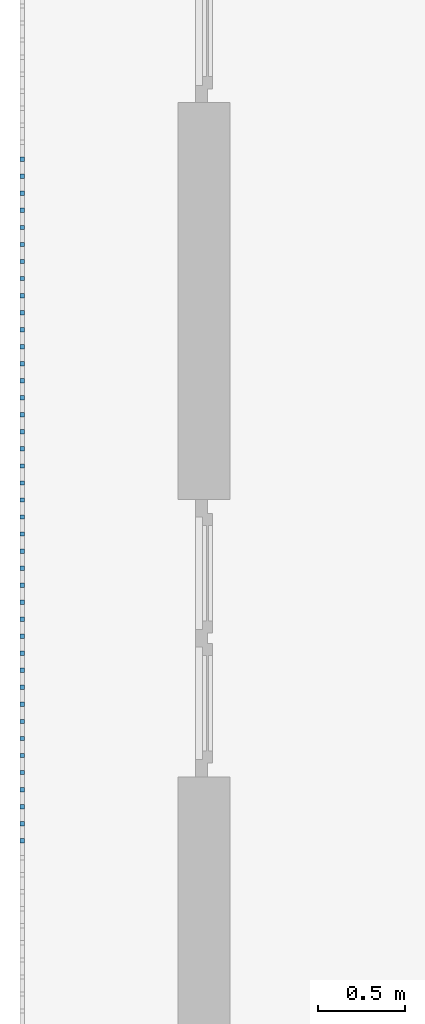
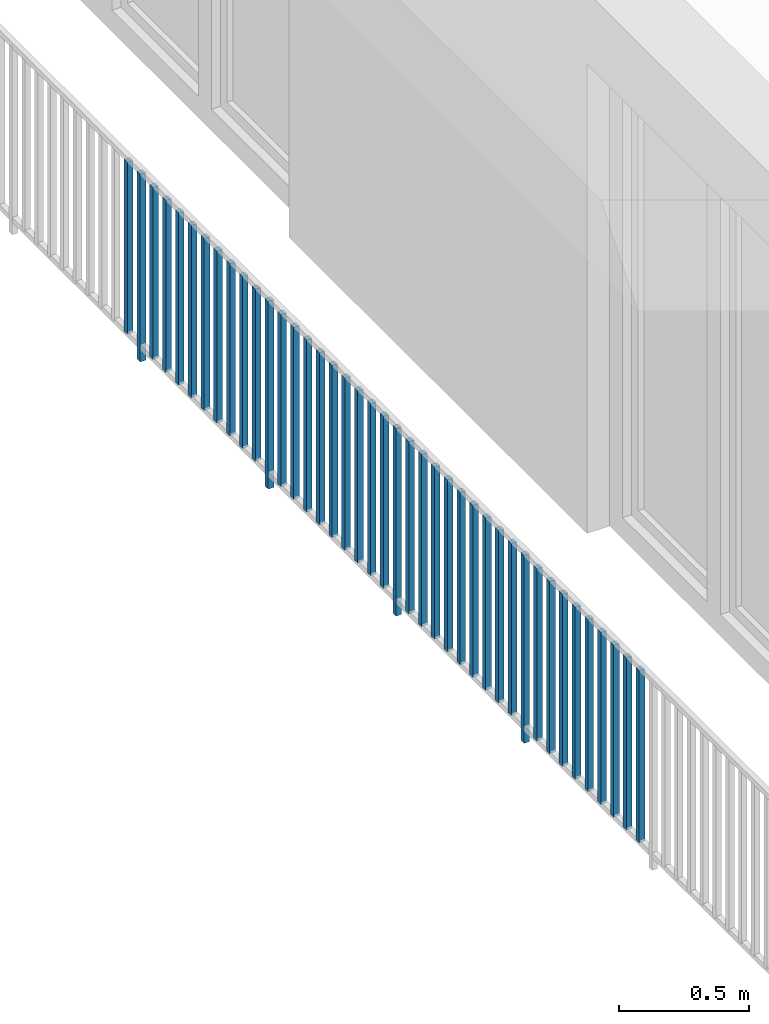
# One storey, part 28 of 48: 41 building element parts, 1 element without a shape of its own.
"""IFC4 building model written with IfcOpenShell, lengths in metres."""

from ifc_helpers import new_model, entity, si_unit, converted_unit, derived_unit, direction, frame, origin_with_axes, place, context, subcontext, project, spatial, polygons, material, type_object, element, aggregate, save


model = new_model("IFC4")

# Units and contexts
model_context = context("Model", 3, precision=1e-05, world=origin_with_axes(), true_north=direction((0.0, 1.0)))
body_context = subcontext(model_context, "Body", "Model", "MODEL_VIEW")
ifc_project = project(units=[si_unit("LENGTHUNIT", "METRE"), si_unit("AREAUNIT", "SQUARE_METRE"), si_unit("VOLUMEUNIT", "CUBIC_METRE"), converted_unit("PLANEANGLEUNIT", "DEGREE", entity("IfcPlaneAngleMeasure", 0.0174532925199), si_unit("PLANEANGLEUNIT", "RADIAN"), dimensions=[0, 0, 0, 0, 0, 0, 0]), converted_unit("TIMEUNIT", "Year", entity("IfcTimeMeasure", 31556926.0), si_unit("TIMEUNIT", "SECOND"), dimensions=[0, 0, 1, 0, 0, 0, 0]), si_unit("MASSUNIT", "GRAM", prefix="KILO"), si_unit("THERMODYNAMICTEMPERATUREUNIT", "DEGREE_CELSIUS"), si_unit("LUMINOUSINTENSITYUNIT", "LUMEN"), si_unit("ENERGYUNIT", "JOULE", prefix="MEGA"), derived_unit("THERMALCONDUCTANCEUNIT", [(si_unit("POWERUNIT", "WATT"), 1), (si_unit("LENGTHUNIT", "METRE"), -1), (si_unit("THERMODYNAMICTEMPERATUREUNIT", "KELVIN"), -1)]), derived_unit("SPECIFICHEATCAPACITYUNIT", [(si_unit("ENERGYUNIT", "JOULE"), 1), (si_unit("MASSUNIT", "GRAM", prefix="KILO"), -1), (si_unit("THERMODYNAMICTEMPERATUREUNIT", "KELVIN"), -1)]), derived_unit("MASSDENSITYUNIT", [(si_unit("MASSUNIT", "GRAM", prefix="KILO"), 1), (si_unit("VOLUMEUNIT", "CUBIC_METRE"), -1)])], contexts=[model_context])

# Site, building, storey
site_placement = place(None, origin_with_axes())
site = spatial("IfcSite", under=ifc_project, at=site_placement, CompositionType="ELEMENT")
building_placement = place(site_placement, origin_with_axes())
building = spatial("IfcBuilding", under=site, at=building_placement, CompositionType="ELEMENT")
storey_placement = place(building_placement, frame((0.0, 0.0, 3.4), z_axis=(0.0, 0.0, 1.0), x_axis=(1.0, 0.0, 0.0)))
storey = spatial("IfcBuildingStorey", under=building, at=storey_placement, Name="1. Geschoss", CompositionType="ELEMENT", Elevation=3.4)

# Railing, building element parts
railing_type = type_object("IfcRailingType", PredefinedType="NOTDEFINED")
railing_placement = place(storey_placement, frame((10.2378006196, 9.82118776896, 0.0), z_axis=(0.0, 0.0, 1.0), x_axis=(1.0, 0.0, 0.0)))
railing = element("IfcRailing", 1, at=railing_placement, inside=storey, type_object=railing_type, PredefinedType="NOTDEFINED")
ifc_material = material()
building_element_part_1_placement = place(railing_placement, origin_with_axes())
building_element_part_1 = element("IfcBuildingElementPart", 2, at=building_element_part_1_placement, material=ifc_material, PredefinedType="NOTDEFINED", context=body_context, shape_type="Tessellation", body=[
    polygons([(-22.8925, -12.6975, 0.07), (-22.8675, -12.6975, 0.07), (-22.8675, -12.6975, 0.8775), (-22.8925, -12.6975, 0.8775), (-22.8925, -12.6725, 0.07), (-22.8675, -12.6725, 0.07), (-22.8675, -12.6725, 0.8775), (-22.8925, -12.6725, 0.8775)], [[[1, 2, 3, 4]], [[1, 5, 6, 2]], [[2, 6, 7, 3]], [[4, 3, 7, 8]], [[5, 1, 4, 8]], [[6, 5, 8, 7]]], closed=True),
])
building_element_part_2_placement = place(railing_placement, origin_with_axes())
building_element_part_2 = element("IfcBuildingElementPart", 3, at=building_element_part_2_placement, material=ifc_material, PredefinedType="NOTDEFINED", context=body_context, shape_type="Tessellation", body=[
    polygons([(-22.8925, -12.7958333333, 0.0), (-22.8675, -12.7958333333, 0.0), (-22.8675, -12.7958333333, 0.88), (-22.8925, -12.7958333333, 0.88), (-22.8925, -12.7708333333, 0.0), (-22.8675, -12.7708333333, 0.0), (-22.8675, -12.7708333333, 0.88), (-22.8925, -12.7708333333, 0.88)], [[[1, 2, 3, 4]], [[1, 5, 6, 2]], [[2, 6, 7, 3]], [[4, 3, 7, 8]], [[5, 1, 4, 8]], [[6, 5, 8, 7]]], closed=True),
])
building_element_part_3_placement = place(railing_placement, origin_with_axes())
building_element_part_3 = element("IfcBuildingElementPart", 4, at=building_element_part_3_placement, material=ifc_material, PredefinedType="NOTDEFINED", context=body_context, shape_type="Tessellation", body=[
    polygons([(-22.8925, -12.8941666667, 0.07), (-22.8675, -12.8941666667, 0.07), (-22.8675, -12.8941666667, 0.8775), (-22.8925, -12.8941666667, 0.8775), (-22.8925, -12.8691666667, 0.07), (-22.8675, -12.8691666667, 0.07), (-22.8675, -12.8691666667, 0.8775), (-22.8925, -12.8691666667, 0.8775)], [[[1, 2, 3, 4]], [[1, 5, 6, 2]], [[2, 6, 7, 3]], [[4, 3, 7, 8]], [[5, 1, 4, 8]], [[6, 5, 8, 7]]], closed=True),
])
building_element_part_4_placement = place(railing_placement, origin_with_axes())
building_element_part_4 = element("IfcBuildingElementPart", 5, at=building_element_part_4_placement, material=ifc_material, PredefinedType="NOTDEFINED", context=body_context, shape_type="Tessellation", body=[
    polygons([(-22.8925, -12.9925, 0.07), (-22.8675, -12.9925, 0.07), (-22.8675, -12.9925, 0.8775), (-22.8925, -12.9925, 0.8775), (-22.8925, -12.9675, 0.07), (-22.8675, -12.9675, 0.07), (-22.8675, -12.9675, 0.8775), (-22.8925, -12.9675, 0.8775)], [[[1, 2, 3, 4]], [[1, 5, 6, 2]], [[2, 6, 7, 3]], [[4, 3, 7, 8]], [[5, 1, 4, 8]], [[6, 5, 8, 7]]], closed=True),
])
building_element_part_5_placement = place(railing_placement, origin_with_axes())
building_element_part_5 = element("IfcBuildingElementPart", 6, at=building_element_part_5_placement, material=ifc_material, PredefinedType="NOTDEFINED", context=body_context, shape_type="Tessellation", body=[
    polygons([(-22.8925, -13.0908333333, 0.07), (-22.8675, -13.0908333333, 0.07), (-22.8675, -13.0908333333, 0.8775), (-22.8925, -13.0908333333, 0.8775), (-22.8925, -13.0658333333, 0.07), (-22.8675, -13.0658333333, 0.07), (-22.8675, -13.0658333333, 0.8775), (-22.8925, -13.0658333333, 0.8775)], [[[1, 2, 3, 4]], [[1, 5, 6, 2]], [[2, 6, 7, 3]], [[4, 3, 7, 8]], [[5, 1, 4, 8]], [[6, 5, 8, 7]]], closed=True),
])
building_element_part_6_placement = place(railing_placement, origin_with_axes())
building_element_part_6 = element("IfcBuildingElementPart", 7, at=building_element_part_6_placement, material=ifc_material, PredefinedType="NOTDEFINED", context=body_context, shape_type="Tessellation", body=[
    polygons([(-22.8925, -13.1891666667, 0.07), (-22.8675, -13.1891666667, 0.07), (-22.8675, -13.1891666667, 0.8775), (-22.8925, -13.1891666667, 0.8775), (-22.8925, -13.1641666667, 0.07), (-22.8675, -13.1641666667, 0.07), (-22.8675, -13.1641666667, 0.8775), (-22.8925, -13.1641666667, 0.8775)], [[[1, 2, 3, 4]], [[1, 5, 6, 2]], [[2, 6, 7, 3]], [[4, 3, 7, 8]], [[5, 1, 4, 8]], [[6, 5, 8, 7]]], closed=True),
])
building_element_part_7_placement = place(railing_placement, origin_with_axes())
building_element_part_7 = element("IfcBuildingElementPart", 8, at=building_element_part_7_placement, material=ifc_material, PredefinedType="NOTDEFINED", context=body_context, shape_type="Tessellation", body=[
    polygons([(-22.8925, -13.2875, 0.07), (-22.8675, -13.2875, 0.07), (-22.8675, -13.2875, 0.8775), (-22.8925, -13.2875, 0.8775), (-22.8925, -13.2625, 0.07), (-22.8675, -13.2625, 0.07), (-22.8675, -13.2625, 0.8775), (-22.8925, -13.2625, 0.8775)], [[[1, 2, 3, 4]], [[1, 5, 6, 2]], [[2, 6, 7, 3]], [[4, 3, 7, 8]], [[5, 1, 4, 8]], [[6, 5, 8, 7]]], closed=True),
])
building_element_part_8_placement = place(railing_placement, origin_with_axes())
building_element_part_8 = element("IfcBuildingElementPart", 9, at=building_element_part_8_placement, material=ifc_material, PredefinedType="NOTDEFINED", context=body_context, shape_type="Tessellation", body=[
    polygons([(-22.8925, -13.3858333333, 0.07), (-22.8675, -13.3858333333, 0.07), (-22.8675, -13.3858333333, 0.8775), (-22.8925, -13.3858333333, 0.8775), (-22.8925, -13.3608333333, 0.07), (-22.8675, -13.3608333333, 0.07), (-22.8675, -13.3608333333, 0.8775), (-22.8925, -13.3608333333, 0.8775)], [[[1, 2, 3, 4]], [[1, 5, 6, 2]], [[2, 6, 7, 3]], [[4, 3, 7, 8]], [[5, 1, 4, 8]], [[6, 5, 8, 7]]], closed=True),
])
building_element_part_9_placement = place(railing_placement, origin_with_axes())
building_element_part_9 = element("IfcBuildingElementPart", 10, at=building_element_part_9_placement, material=ifc_material, PredefinedType="NOTDEFINED", context=body_context, shape_type="Tessellation", body=[
    polygons([(-22.8925, -13.4841666667, 0.07), (-22.8675, -13.4841666667, 0.07), (-22.8675, -13.4841666667, 0.8775), (-22.8925, -13.4841666667, 0.8775), (-22.8925, -13.4591666667, 0.07), (-22.8675, -13.4591666667, 0.07), (-22.8675, -13.4591666667, 0.8775), (-22.8925, -13.4591666667, 0.8775)], [[[1, 2, 3, 4]], [[1, 5, 6, 2]], [[2, 6, 7, 3]], [[4, 3, 7, 8]], [[5, 1, 4, 8]], [[6, 5, 8, 7]]], closed=True),
])
building_element_part_10_placement = place(railing_placement, origin_with_axes())
building_element_part_10 = element("IfcBuildingElementPart", 11, at=building_element_part_10_placement, material=ifc_material, PredefinedType="NOTDEFINED", context=body_context, shape_type="Tessellation", body=[
    polygons([(-22.8925, -13.5825, 0.07), (-22.8675, -13.5825, 0.07), (-22.8675, -13.5825, 0.8775), (-22.8925, -13.5825, 0.8775), (-22.8925, -13.5575, 0.07), (-22.8675, -13.5575, 0.07), (-22.8675, -13.5575, 0.8775), (-22.8925, -13.5575, 0.8775)], [[[1, 2, 3, 4]], [[1, 5, 6, 2]], [[2, 6, 7, 3]], [[4, 3, 7, 8]], [[5, 1, 4, 8]], [[6, 5, 8, 7]]], closed=True),
])
building_element_part_11_placement = place(railing_placement, origin_with_axes())
building_element_part_11 = element("IfcBuildingElementPart", 12, at=building_element_part_11_placement, material=ifc_material, PredefinedType="NOTDEFINED", context=body_context, shape_type="Tessellation", body=[
    polygons([(-22.8925, -13.6808333333, 0.07), (-22.8675, -13.6808333333, 0.07), (-22.8675, -13.6808333333, 0.8775), (-22.8925, -13.6808333333, 0.8775), (-22.8925, -13.6558333333, 0.07), (-22.8675, -13.6558333333, 0.07), (-22.8675, -13.6558333333, 0.8775), (-22.8925, -13.6558333333, 0.8775)], [[[1, 2, 3, 4]], [[1, 5, 6, 2]], [[2, 6, 7, 3]], [[4, 3, 7, 8]], [[5, 1, 4, 8]], [[6, 5, 8, 7]]], closed=True),
])
building_element_part_12_placement = place(railing_placement, origin_with_axes())
building_element_part_12 = element("IfcBuildingElementPart", 13, at=building_element_part_12_placement, material=ifc_material, PredefinedType="NOTDEFINED", context=body_context, shape_type="Tessellation", body=[
    polygons([(-22.8925, -13.7791666667, 0.0), (-22.8675, -13.7791666667, 0.0), (-22.8675, -13.7791666667, 0.88), (-22.8925, -13.7791666667, 0.88), (-22.8925, -13.7541666667, 0.0), (-22.8675, -13.7541666667, 0.0), (-22.8675, -13.7541666667, 0.88), (-22.8925, -13.7541666667, 0.88)], [[[1, 2, 3, 4]], [[1, 5, 6, 2]], [[2, 6, 7, 3]], [[4, 3, 7, 8]], [[5, 1, 4, 8]], [[6, 5, 8, 7]]], closed=True),
])
building_element_part_13_placement = place(railing_placement, origin_with_axes())
building_element_part_13 = element("IfcBuildingElementPart", 14, at=building_element_part_13_placement, material=ifc_material, PredefinedType="NOTDEFINED", context=body_context, shape_type="Tessellation", body=[
    polygons([(-22.8925, -13.8775, 0.07), (-22.8675, -13.8775, 0.07), (-22.8675, -13.8775, 0.8775), (-22.8925, -13.8775, 0.8775), (-22.8925, -13.8525, 0.07), (-22.8675, -13.8525, 0.07), (-22.8675, -13.8525, 0.8775), (-22.8925, -13.8525, 0.8775)], [[[1, 2, 3, 4]], [[1, 5, 6, 2]], [[2, 6, 7, 3]], [[4, 3, 7, 8]], [[5, 1, 4, 8]], [[6, 5, 8, 7]]], closed=True),
])
building_element_part_14_placement = place(railing_placement, origin_with_axes())
building_element_part_14 = element("IfcBuildingElementPart", 15, at=building_element_part_14_placement, material=ifc_material, PredefinedType="NOTDEFINED", context=body_context, shape_type="Tessellation", body=[
    polygons([(-22.8925, -13.9758333333, 0.07), (-22.8675, -13.9758333333, 0.07), (-22.8675, -13.9758333333, 0.8775), (-22.8925, -13.9758333333, 0.8775), (-22.8925, -13.9508333333, 0.07), (-22.8675, -13.9508333333, 0.07), (-22.8675, -13.9508333333, 0.8775), (-22.8925, -13.9508333333, 0.8775)], [[[1, 2, 3, 4]], [[1, 5, 6, 2]], [[2, 6, 7, 3]], [[4, 3, 7, 8]], [[5, 1, 4, 8]], [[6, 5, 8, 7]]], closed=True),
])
building_element_part_15_placement = place(railing_placement, origin_with_axes())
building_element_part_15 = element("IfcBuildingElementPart", 16, at=building_element_part_15_placement, material=ifc_material, PredefinedType="NOTDEFINED", context=body_context, shape_type="Tessellation", body=[
    polygons([(-22.8925, -14.0741666667, 0.07), (-22.8675, -14.0741666667, 0.07), (-22.8675, -14.0741666667, 0.8775), (-22.8925, -14.0741666667, 0.8775), (-22.8925, -14.0491666667, 0.07), (-22.8675, -14.0491666667, 0.07), (-22.8675, -14.0491666667, 0.8775), (-22.8925, -14.0491666667, 0.8775)], [[[1, 2, 3, 4]], [[1, 5, 6, 2]], [[2, 6, 7, 3]], [[4, 3, 7, 8]], [[5, 1, 4, 8]], [[6, 5, 8, 7]]], closed=True),
])
building_element_part_16_placement = place(railing_placement, origin_with_axes())
building_element_part_16 = element("IfcBuildingElementPart", 17, at=building_element_part_16_placement, material=ifc_material, PredefinedType="NOTDEFINED", context=body_context, shape_type="Tessellation", body=[
    polygons([(-22.8925, -14.1725, 0.07), (-22.8675, -14.1725, 0.07), (-22.8675, -14.1725, 0.8775), (-22.8925, -14.1725, 0.8775), (-22.8925, -14.1475, 0.07), (-22.8675, -14.1475, 0.07), (-22.8675, -14.1475, 0.8775), (-22.8925, -14.1475, 0.8775)], [[[1, 2, 3, 4]], [[1, 5, 6, 2]], [[2, 6, 7, 3]], [[4, 3, 7, 8]], [[5, 1, 4, 8]], [[6, 5, 8, 7]]], closed=True),
])
building_element_part_17_placement = place(railing_placement, origin_with_axes())
building_element_part_17 = element("IfcBuildingElementPart", 18, at=building_element_part_17_placement, material=ifc_material, PredefinedType="NOTDEFINED", context=body_context, shape_type="Tessellation", body=[
    polygons([(-22.8925, -14.2708333333, 0.07), (-22.8675, -14.2708333333, 0.07), (-22.8675, -14.2708333333, 0.8775), (-22.8925, -14.2708333333, 0.8775), (-22.8925, -14.2458333333, 0.07), (-22.8675, -14.2458333333, 0.07), (-22.8675, -14.2458333333, 0.8775), (-22.8925, -14.2458333333, 0.8775)], [[[1, 2, 3, 4]], [[1, 5, 6, 2]], [[2, 6, 7, 3]], [[4, 3, 7, 8]], [[5, 1, 4, 8]], [[6, 5, 8, 7]]], closed=True),
])
building_element_part_18_placement = place(railing_placement, origin_with_axes())
building_element_part_18 = element("IfcBuildingElementPart", 19, at=building_element_part_18_placement, material=ifc_material, PredefinedType="NOTDEFINED", context=body_context, shape_type="Tessellation", body=[
    polygons([(-22.8925, -14.3691666667, 0.07), (-22.8675, -14.3691666667, 0.07), (-22.8675, -14.3691666667, 0.8775), (-22.8925, -14.3691666667, 0.8775), (-22.8925, -14.3441666667, 0.07), (-22.8675, -14.3441666667, 0.07), (-22.8675, -14.3441666667, 0.8775), (-22.8925, -14.3441666667, 0.8775)], [[[1, 2, 3, 4]], [[1, 5, 6, 2]], [[2, 6, 7, 3]], [[4, 3, 7, 8]], [[5, 1, 4, 8]], [[6, 5, 8, 7]]], closed=True),
])
building_element_part_19_placement = place(railing_placement, origin_with_axes())
building_element_part_19 = element("IfcBuildingElementPart", 20, at=building_element_part_19_placement, material=ifc_material, PredefinedType="NOTDEFINED", context=body_context, shape_type="Tessellation", body=[
    polygons([(-22.8925, -14.4675, 0.07), (-22.8675, -14.4675, 0.07), (-22.8675, -14.4675, 0.8775), (-22.8925, -14.4675, 0.8775), (-22.8925, -14.4425, 0.07), (-22.8675, -14.4425, 0.07), (-22.8675, -14.4425, 0.8775), (-22.8925, -14.4425, 0.8775)], [[[1, 2, 3, 4]], [[1, 5, 6, 2]], [[2, 6, 7, 3]], [[4, 3, 7, 8]], [[5, 1, 4, 8]], [[6, 5, 8, 7]]], closed=True),
])
building_element_part_20_placement = place(railing_placement, origin_with_axes())
building_element_part_20 = element("IfcBuildingElementPart", 21, at=building_element_part_20_placement, material=ifc_material, PredefinedType="NOTDEFINED", context=body_context, shape_type="Tessellation", body=[
    polygons([(-22.8925, -14.5658333333, 0.07), (-22.8675, -14.5658333333, 0.07), (-22.8675, -14.5658333333, 0.8775), (-22.8925, -14.5658333333, 0.8775), (-22.8925, -14.5408333333, 0.07), (-22.8675, -14.5408333333, 0.07), (-22.8675, -14.5408333333, 0.8775), (-22.8925, -14.5408333333, 0.8775)], [[[1, 2, 3, 4]], [[1, 5, 6, 2]], [[2, 6, 7, 3]], [[4, 3, 7, 8]], [[5, 1, 4, 8]], [[6, 5, 8, 7]]], closed=True),
])
building_element_part_21_placement = place(railing_placement, origin_with_axes())
building_element_part_21 = element("IfcBuildingElementPart", 22, at=building_element_part_21_placement, material=ifc_material, PredefinedType="NOTDEFINED", context=body_context, shape_type="Tessellation", body=[
    polygons([(-22.8925, -14.6641666667, 0.07), (-22.8675, -14.6641666667, 0.07), (-22.8675, -14.6641666667, 0.8775), (-22.8925, -14.6641666667, 0.8775), (-22.8925, -14.6391666667, 0.07), (-22.8675, -14.6391666667, 0.07), (-22.8675, -14.6391666667, 0.8775), (-22.8925, -14.6391666667, 0.8775)], [[[1, 2, 3, 4]], [[1, 5, 6, 2]], [[2, 6, 7, 3]], [[4, 3, 7, 8]], [[5, 1, 4, 8]], [[6, 5, 8, 7]]], closed=True),
])
building_element_part_22_placement = place(railing_placement, origin_with_axes())
building_element_part_22 = element("IfcBuildingElementPart", 23, at=building_element_part_22_placement, material=ifc_material, PredefinedType="NOTDEFINED", context=body_context, shape_type="Tessellation", body=[
    polygons([(-22.8925, -14.7625, 0.0), (-22.8675, -14.7625, 0.0), (-22.8675, -14.7625, 0.88), (-22.8925, -14.7625, 0.88), (-22.8925, -14.7375, 0.0), (-22.8675, -14.7375, 0.0), (-22.8675, -14.7375, 0.88), (-22.8925, -14.7375, 0.88)], [[[1, 2, 3, 4]], [[1, 5, 6, 2]], [[2, 6, 7, 3]], [[4, 3, 7, 8]], [[5, 1, 4, 8]], [[6, 5, 8, 7]]], closed=True),
])
building_element_part_23_placement = place(railing_placement, origin_with_axes())
building_element_part_23 = element("IfcBuildingElementPart", 24, at=building_element_part_23_placement, material=ifc_material, PredefinedType="NOTDEFINED", context=body_context, shape_type="Tessellation", body=[
    polygons([(-22.8925, -14.8608333333, 0.07), (-22.8675, -14.8608333333, 0.07), (-22.8675, -14.8608333333, 0.8775), (-22.8925, -14.8608333333, 0.8775), (-22.8925, -14.8358333333, 0.07), (-22.8675, -14.8358333333, 0.07), (-22.8675, -14.8358333333, 0.8775), (-22.8925, -14.8358333333, 0.8775)], [[[1, 2, 3, 4]], [[1, 5, 6, 2]], [[2, 6, 7, 3]], [[4, 3, 7, 8]], [[5, 1, 4, 8]], [[6, 5, 8, 7]]], closed=True),
])
building_element_part_24_placement = place(railing_placement, origin_with_axes())
building_element_part_24 = element("IfcBuildingElementPart", 25, at=building_element_part_24_placement, material=ifc_material, PredefinedType="NOTDEFINED", context=body_context, shape_type="Tessellation", body=[
    polygons([(-22.8925, -14.9591666667, 0.07), (-22.8675, -14.9591666667, 0.07), (-22.8675, -14.9591666667, 0.8775), (-22.8925, -14.9591666667, 0.8775), (-22.8925, -14.9341666667, 0.07), (-22.8675, -14.9341666667, 0.07), (-22.8675, -14.9341666667, 0.8775), (-22.8925, -14.9341666667, 0.8775)], [[[1, 2, 3, 4]], [[1, 5, 6, 2]], [[2, 6, 7, 3]], [[4, 3, 7, 8]], [[5, 1, 4, 8]], [[6, 5, 8, 7]]], closed=True),
])
building_element_part_25_placement = place(railing_placement, origin_with_axes())
building_element_part_25 = element("IfcBuildingElementPart", 26, at=building_element_part_25_placement, material=ifc_material, PredefinedType="NOTDEFINED", context=body_context, shape_type="Tessellation", body=[
    polygons([(-22.8925, -15.0575, 0.07), (-22.8675, -15.0575, 0.07), (-22.8675, -15.0575, 0.8775), (-22.8925, -15.0575, 0.8775), (-22.8925, -15.0325, 0.07), (-22.8675, -15.0325, 0.07), (-22.8675, -15.0325, 0.8775), (-22.8925, -15.0325, 0.8775)], [[[1, 2, 3, 4]], [[1, 5, 6, 2]], [[2, 6, 7, 3]], [[4, 3, 7, 8]], [[5, 1, 4, 8]], [[6, 5, 8, 7]]], closed=True),
])
building_element_part_26_placement = place(railing_placement, origin_with_axes())
building_element_part_26 = element("IfcBuildingElementPart", 27, at=building_element_part_26_placement, material=ifc_material, PredefinedType="NOTDEFINED", context=body_context, shape_type="Tessellation", body=[
    polygons([(-22.8925, -15.1558333333, 0.07), (-22.8675, -15.1558333333, 0.07), (-22.8675, -15.1558333333, 0.8775), (-22.8925, -15.1558333333, 0.8775), (-22.8925, -15.1308333333, 0.07), (-22.8675, -15.1308333333, 0.07), (-22.8675, -15.1308333333, 0.8775), (-22.8925, -15.1308333333, 0.8775)], [[[1, 2, 3, 4]], [[1, 5, 6, 2]], [[2, 6, 7, 3]], [[4, 3, 7, 8]], [[5, 1, 4, 8]], [[6, 5, 8, 7]]], closed=True),
])
building_element_part_27_placement = place(railing_placement, origin_with_axes())
building_element_part_27 = element("IfcBuildingElementPart", 28, at=building_element_part_27_placement, material=ifc_material, PredefinedType="NOTDEFINED", context=body_context, shape_type="Tessellation", body=[
    polygons([(-22.8925, -15.2541666667, 0.07), (-22.8675, -15.2541666667, 0.07), (-22.8675, -15.2541666667, 0.8775), (-22.8925, -15.2541666667, 0.8775), (-22.8925, -15.2291666667, 0.07), (-22.8675, -15.2291666667, 0.07), (-22.8675, -15.2291666667, 0.8775), (-22.8925, -15.2291666667, 0.8775)], [[[1, 2, 3, 4]], [[1, 5, 6, 2]], [[2, 6, 7, 3]], [[4, 3, 7, 8]], [[5, 1, 4, 8]], [[6, 5, 8, 7]]], closed=True),
])
building_element_part_28_placement = place(railing_placement, origin_with_axes())
building_element_part_28 = element("IfcBuildingElementPart", 29, at=building_element_part_28_placement, material=ifc_material, PredefinedType="NOTDEFINED", context=body_context, shape_type="Tessellation", body=[
    polygons([(-22.8925, -15.3525, 0.07), (-22.8675, -15.3525, 0.07), (-22.8675, -15.3525, 0.8775), (-22.8925, -15.3525, 0.8775), (-22.8925, -15.3275, 0.07), (-22.8675, -15.3275, 0.07), (-22.8675, -15.3275, 0.8775), (-22.8925, -15.3275, 0.8775)], [[[1, 2, 3, 4]], [[1, 5, 6, 2]], [[2, 6, 7, 3]], [[4, 3, 7, 8]], [[5, 1, 4, 8]], [[6, 5, 8, 7]]], closed=True),
])
building_element_part_29_placement = place(railing_placement, origin_with_axes())
building_element_part_29 = element("IfcBuildingElementPart", 30, at=building_element_part_29_placement, material=ifc_material, PredefinedType="NOTDEFINED", context=body_context, shape_type="Tessellation", body=[
    polygons([(-22.8925, -15.4508333333, 0.07), (-22.8675, -15.4508333333, 0.07), (-22.8675, -15.4508333333, 0.8775), (-22.8925, -15.4508333333, 0.8775), (-22.8925, -15.4258333333, 0.07), (-22.8675, -15.4258333333, 0.07), (-22.8675, -15.4258333333, 0.8775), (-22.8925, -15.4258333333, 0.8775)], [[[1, 2, 3, 4]], [[1, 5, 6, 2]], [[2, 6, 7, 3]], [[4, 3, 7, 8]], [[5, 1, 4, 8]], [[6, 5, 8, 7]]], closed=True),
])
building_element_part_30_placement = place(railing_placement, origin_with_axes())
building_element_part_30 = element("IfcBuildingElementPart", 31, at=building_element_part_30_placement, material=ifc_material, PredefinedType="NOTDEFINED", context=body_context, shape_type="Tessellation", body=[
    polygons([(-22.8925, -15.5491666667, 0.07), (-22.8675, -15.5491666667, 0.07), (-22.8675, -15.5491666667, 0.8775), (-22.8925, -15.5491666667, 0.8775), (-22.8925, -15.5241666667, 0.07), (-22.8675, -15.5241666667, 0.07), (-22.8675, -15.5241666667, 0.8775), (-22.8925, -15.5241666667, 0.8775)], [[[1, 2, 3, 4]], [[1, 5, 6, 2]], [[2, 6, 7, 3]], [[4, 3, 7, 8]], [[5, 1, 4, 8]], [[6, 5, 8, 7]]], closed=True),
])
building_element_part_31_placement = place(railing_placement, origin_with_axes())
building_element_part_31 = element("IfcBuildingElementPart", 32, at=building_element_part_31_placement, material=ifc_material, PredefinedType="NOTDEFINED", context=body_context, shape_type="Tessellation", body=[
    polygons([(-22.8925, -15.6475, 0.07), (-22.8675, -15.6475, 0.07), (-22.8675, -15.6475, 0.8775), (-22.8925, -15.6475, 0.8775), (-22.8925, -15.6225, 0.07), (-22.8675, -15.6225, 0.07), (-22.8675, -15.6225, 0.8775), (-22.8925, -15.6225, 0.8775)], [[[1, 2, 3, 4]], [[1, 5, 6, 2]], [[2, 6, 7, 3]], [[4, 3, 7, 8]], [[5, 1, 4, 8]], [[6, 5, 8, 7]]], closed=True),
])
building_element_part_32_placement = place(railing_placement, origin_with_axes())
building_element_part_32 = element("IfcBuildingElementPart", 33, at=building_element_part_32_placement, material=ifc_material, PredefinedType="NOTDEFINED", context=body_context, shape_type="Tessellation", body=[
    polygons([(-22.8925, -15.7458333333, 0.0), (-22.8675, -15.7458333333, 0.0), (-22.8675, -15.7458333333, 0.88), (-22.8925, -15.7458333333, 0.88), (-22.8925, -15.7208333333, 0.0), (-22.8675, -15.7208333333, 0.0), (-22.8675, -15.7208333333, 0.88), (-22.8925, -15.7208333333, 0.88)], [[[1, 2, 3, 4]], [[1, 5, 6, 2]], [[2, 6, 7, 3]], [[4, 3, 7, 8]], [[5, 1, 4, 8]], [[6, 5, 8, 7]]], closed=True),
])
building_element_part_33_placement = place(railing_placement, origin_with_axes())
building_element_part_33 = element("IfcBuildingElementPart", 34, at=building_element_part_33_placement, material=ifc_material, PredefinedType="NOTDEFINED", context=body_context, shape_type="Tessellation", body=[
    polygons([(-22.8925, -15.8441666667, 0.07), (-22.8675, -15.8441666667, 0.07), (-22.8675, -15.8441666667, 0.8775), (-22.8925, -15.8441666667, 0.8775), (-22.8925, -15.8191666667, 0.07), (-22.8675, -15.8191666667, 0.07), (-22.8675, -15.8191666667, 0.8775), (-22.8925, -15.8191666667, 0.8775)], [[[1, 2, 3, 4]], [[1, 5, 6, 2]], [[2, 6, 7, 3]], [[4, 3, 7, 8]], [[5, 1, 4, 8]], [[6, 5, 8, 7]]], closed=True),
])
building_element_part_34_placement = place(railing_placement, origin_with_axes())
building_element_part_34 = element("IfcBuildingElementPart", 35, at=building_element_part_34_placement, material=ifc_material, PredefinedType="NOTDEFINED", context=body_context, shape_type="Tessellation", body=[
    polygons([(-22.8925, -15.9425, 0.07), (-22.8675, -15.9425, 0.07), (-22.8675, -15.9425, 0.8775), (-22.8925, -15.9425, 0.8775), (-22.8925, -15.9175, 0.07), (-22.8675, -15.9175, 0.07), (-22.8675, -15.9175, 0.8775), (-22.8925, -15.9175, 0.8775)], [[[1, 2, 3, 4]], [[1, 5, 6, 2]], [[2, 6, 7, 3]], [[4, 3, 7, 8]], [[5, 1, 4, 8]], [[6, 5, 8, 7]]], closed=True),
])
building_element_part_35_placement = place(railing_placement, origin_with_axes())
building_element_part_35 = element("IfcBuildingElementPart", 36, at=building_element_part_35_placement, material=ifc_material, PredefinedType="NOTDEFINED", context=body_context, shape_type="Tessellation", body=[
    polygons([(-22.8925, -16.0408333333, 0.07), (-22.8675, -16.0408333333, 0.07), (-22.8675, -16.0408333333, 0.8775), (-22.8925, -16.0408333333, 0.8775), (-22.8925, -16.0158333333, 0.07), (-22.8675, -16.0158333333, 0.07), (-22.8675, -16.0158333333, 0.8775), (-22.8925, -16.0158333333, 0.8775)], [[[1, 2, 3, 4]], [[1, 5, 6, 2]], [[2, 6, 7, 3]], [[4, 3, 7, 8]], [[5, 1, 4, 8]], [[6, 5, 8, 7]]], closed=True),
])
building_element_part_36_placement = place(railing_placement, origin_with_axes())
building_element_part_36 = element("IfcBuildingElementPart", 37, at=building_element_part_36_placement, material=ifc_material, PredefinedType="NOTDEFINED", context=body_context, shape_type="Tessellation", body=[
    polygons([(-22.8925, -16.1391666667, 0.07), (-22.8675, -16.1391666667, 0.07), (-22.8675, -16.1391666667, 0.8775), (-22.8925, -16.1391666667, 0.8775), (-22.8925, -16.1141666667, 0.07), (-22.8675, -16.1141666667, 0.07), (-22.8675, -16.1141666667, 0.8775), (-22.8925, -16.1141666667, 0.8775)], [[[1, 2, 3, 4]], [[1, 5, 6, 2]], [[2, 6, 7, 3]], [[4, 3, 7, 8]], [[5, 1, 4, 8]], [[6, 5, 8, 7]]], closed=True),
])
building_element_part_37_placement = place(railing_placement, origin_with_axes())
building_element_part_37 = element("IfcBuildingElementPart", 38, at=building_element_part_37_placement, material=ifc_material, PredefinedType="NOTDEFINED", context=body_context, shape_type="Tessellation", body=[
    polygons([(-22.8925, -16.2375, 0.07), (-22.8675, -16.2375, 0.07), (-22.8675, -16.2375, 0.8775), (-22.8925, -16.2375, 0.8775), (-22.8925, -16.2125, 0.07), (-22.8675, -16.2125, 0.07), (-22.8675, -16.2125, 0.8775), (-22.8925, -16.2125, 0.8775)], [[[1, 2, 3, 4]], [[1, 5, 6, 2]], [[2, 6, 7, 3]], [[4, 3, 7, 8]], [[5, 1, 4, 8]], [[6, 5, 8, 7]]], closed=True),
])
building_element_part_38_placement = place(railing_placement, origin_with_axes())
building_element_part_38 = element("IfcBuildingElementPart", 39, at=building_element_part_38_placement, material=ifc_material, PredefinedType="NOTDEFINED", context=body_context, shape_type="Tessellation", body=[
    polygons([(-22.8925, -16.3358333333, 0.07), (-22.8675, -16.3358333333, 0.07), (-22.8675, -16.3358333333, 0.8775), (-22.8925, -16.3358333333, 0.8775), (-22.8925, -16.3108333333, 0.07), (-22.8675, -16.3108333333, 0.07), (-22.8675, -16.3108333333, 0.8775), (-22.8925, -16.3108333333, 0.8775)], [[[1, 2, 3, 4]], [[1, 5, 6, 2]], [[2, 6, 7, 3]], [[4, 3, 7, 8]], [[5, 1, 4, 8]], [[6, 5, 8, 7]]], closed=True),
])
building_element_part_39_placement = place(railing_placement, origin_with_axes())
building_element_part_39 = element("IfcBuildingElementPart", 40, at=building_element_part_39_placement, material=ifc_material, PredefinedType="NOTDEFINED", context=body_context, shape_type="Tessellation", body=[
    polygons([(-22.8925, -16.4341666667, 0.07), (-22.8675, -16.4341666667, 0.07), (-22.8675, -16.4341666667, 0.8775), (-22.8925, -16.4341666667, 0.8775), (-22.8925, -16.4091666667, 0.07), (-22.8675, -16.4091666667, 0.07), (-22.8675, -16.4091666667, 0.8775), (-22.8925, -16.4091666667, 0.8775)], [[[1, 2, 3, 4]], [[1, 5, 6, 2]], [[2, 6, 7, 3]], [[4, 3, 7, 8]], [[5, 1, 4, 8]], [[6, 5, 8, 7]]], closed=True),
])
building_element_part_40_placement = place(railing_placement, origin_with_axes())
building_element_part_40 = element("IfcBuildingElementPart", 41, at=building_element_part_40_placement, material=ifc_material, PredefinedType="NOTDEFINED", context=body_context, shape_type="Tessellation", body=[
    polygons([(-22.8925, -16.5325, 0.07), (-22.8675, -16.5325, 0.07), (-22.8675, -16.5325, 0.8775), (-22.8925, -16.5325, 0.8775), (-22.8925, -16.5075, 0.07), (-22.8675, -16.5075, 0.07), (-22.8675, -16.5075, 0.8775), (-22.8925, -16.5075, 0.8775)], [[[1, 2, 3, 4]], [[1, 5, 6, 2]], [[2, 6, 7, 3]], [[4, 3, 7, 8]], [[5, 1, 4, 8]], [[6, 5, 8, 7]]], closed=True),
])
building_element_part_41_placement = place(railing_placement, origin_with_axes())
building_element_part_41 = element("IfcBuildingElementPart", 42, at=building_element_part_41_placement, material=ifc_material, PredefinedType="NOTDEFINED", context=body_context, shape_type="Tessellation", body=[
    polygons([(-22.8925, -16.6308333333, 0.07), (-22.8675, -16.6308333333, 0.07), (-22.8675, -16.6308333333, 0.8775), (-22.8925, -16.6308333333, 0.8775), (-22.8925, -16.6058333333, 0.07), (-22.8675, -16.6058333333, 0.07), (-22.8675, -16.6058333333, 0.8775), (-22.8925, -16.6058333333, 0.8775)], [[[1, 2, 3, 4]], [[1, 5, 6, 2]], [[2, 6, 7, 3]], [[4, 3, 7, 8]], [[5, 1, 4, 8]], [[6, 5, 8, 7]]], closed=True),
])
aggregate(railing, [building_element_part_1, building_element_part_2, building_element_part_3, building_element_part_4, building_element_part_5, building_element_part_6, building_element_part_7, building_element_part_8, building_element_part_9, building_element_part_10, building_element_part_11, building_element_part_12, building_element_part_13, building_element_part_14, building_element_part_15, building_element_part_16, building_element_part_17, building_element_part_18, building_element_part_19, building_element_part_20, building_element_part_21, building_element_part_22, building_element_part_23, building_element_part_24, building_element_part_25, building_element_part_26, building_element_part_27, building_element_part_28, building_element_part_29, building_element_part_30, building_element_part_31, building_element_part_32, building_element_part_33, building_element_part_34, building_element_part_35, building_element_part_36, building_element_part_37, building_element_part_38, building_element_part_39, building_element_part_40, building_element_part_41])

save(model, "model.ifc")
